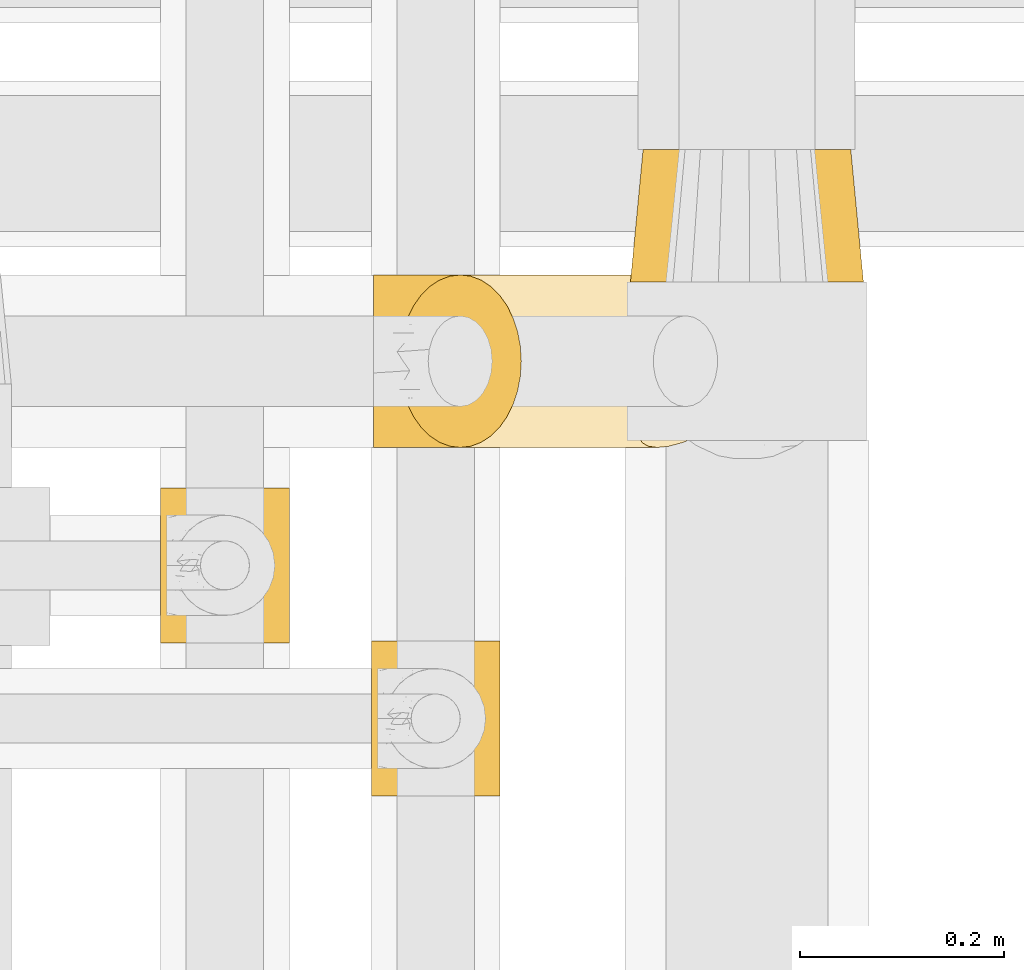
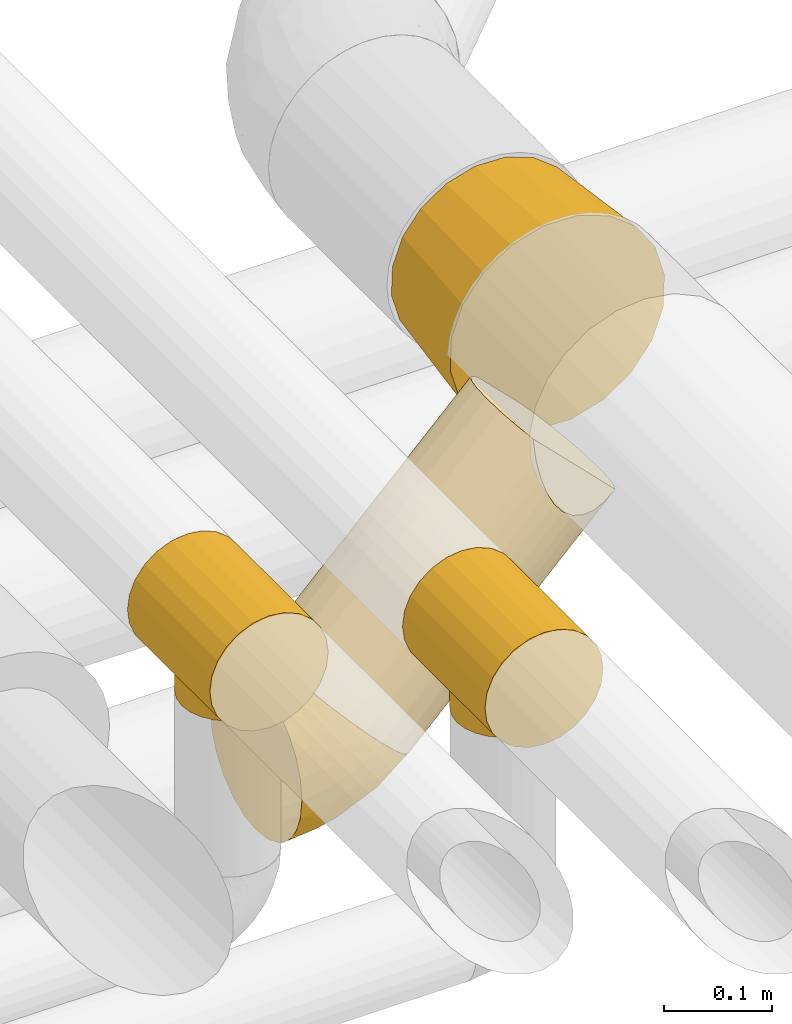
# One storey, part 32 of 93: 5 coverings.
"""IFC2X3 building model written with IfcOpenShell, lengths in millimetres."""

from ifc_helpers import new_model, entity, si_unit, converted_unit, derived_unit, direction, frame, origin, place, context, subcontext, project, spatial, faceted_brep, element, save


model = new_model("IFC2X3")

# Units and contexts
model_context = context("Model", 3, precision=0.01, world=origin(), true_north=direction((6.12303176911189e-17, 1.0)))
body_context = subcontext(model_context, "Body", "Model", "MODEL_VIEW")
ifc_project = project(units=[si_unit("LENGTHUNIT", "METRE", prefix="MILLI"), si_unit("AREAUNIT", "SQUARE_METRE"), si_unit("VOLUMEUNIT", "CUBIC_METRE"), converted_unit("PLANEANGLEUNIT", "DEGREE", entity("IfcRatioMeasure", 0.0174532925199433), si_unit("PLANEANGLEUNIT", "RADIAN"), dimensions=[0, 0, 0, 0, 0, 0, 0]), si_unit("MASSUNIT", "GRAM", prefix="KILO"), derived_unit("MASSDENSITYUNIT", [(si_unit("MASSUNIT", "GRAM", prefix="KILO"), 1), (si_unit("LENGTHUNIT", "METRE"), -3)]), derived_unit("MOMENTOFINERTIAUNIT", [(si_unit("LENGTHUNIT", "METRE"), 4)]), si_unit("TIMEUNIT", "SECOND"), si_unit("FREQUENCYUNIT", "HERTZ"), si_unit("THERMODYNAMICTEMPERATUREUNIT", "DEGREE_CELSIUS"), derived_unit("THERMALTRANSMITTANCEUNIT", [(si_unit("MASSUNIT", "GRAM", prefix="KILO"), 1), (si_unit("THERMODYNAMICTEMPERATUREUNIT", "KELVIN"), -1), (si_unit("TIMEUNIT", "SECOND"), -3)]), derived_unit("VOLUMETRICFLOWRATEUNIT", [(si_unit("LENGTHUNIT", "METRE"), 3), (si_unit("TIMEUNIT", "SECOND"), -1)]), derived_unit("MASSFLOWRATEUNIT", [(si_unit("MASSUNIT", "GRAM", prefix="KILO"), 1), (si_unit("TIMEUNIT", "SECOND"), -1)]), derived_unit("ROTATIONALFREQUENCYUNIT", [(si_unit("TIMEUNIT", "SECOND"), -1)]), si_unit("ELECTRICCURRENTUNIT", "AMPERE"), si_unit("ELECTRICVOLTAGEUNIT", "VOLT"), si_unit("POWERUNIT", "WATT"), si_unit("FORCEUNIT", "NEWTON", prefix="KILO"), si_unit("ILLUMINANCEUNIT", "LUX"), si_unit("LUMINOUSFLUXUNIT", "LUMEN"), si_unit("LUMINOUSINTENSITYUNIT", "CANDELA"), derived_unit("USERDEFINED", [(si_unit("MASSUNIT", "GRAM", prefix="KILO"), -1), (si_unit("LENGTHUNIT", "METRE"), -2), (si_unit("TIMEUNIT", "SECOND"), 3), (si_unit("LUMINOUSFLUXUNIT", "LUMEN"), 1)]), derived_unit("LINEARVELOCITYUNIT", [(si_unit("LENGTHUNIT", "METRE"), 1), (si_unit("TIMEUNIT", "SECOND"), -1)]), si_unit("PRESSUREUNIT", "PASCAL"), derived_unit("USERDEFINED", [(si_unit("LENGTHUNIT", "METRE"), -2), (si_unit("MASSUNIT", "GRAM", prefix="KILO"), 1), (si_unit("TIMEUNIT", "SECOND"), -2)]), derived_unit("LINEARFORCEUNIT", [(si_unit("MASSUNIT", "GRAM", prefix="KILO"), 1), (si_unit("LENGTHUNIT", "METRE"), 1), (si_unit("TIMEUNIT", "SECOND"), -2), (si_unit("LENGTHUNIT", "METRE"), -1)]), derived_unit("PLANARFORCEUNIT", [(si_unit("MASSUNIT", "GRAM", prefix="KILO"), 1), (si_unit("LENGTHUNIT", "METRE"), 1), (si_unit("TIMEUNIT", "SECOND"), -2), (si_unit("LENGTHUNIT", "METRE"), -2)])], contexts=[model_context])

# Site, building, storey
site_placement = place(None, origin())
site = spatial("IfcSite", under=ifc_project, at=site_placement, CompositionType="ELEMENT")
building_placement = place(site_placement, origin())
building = spatial("IfcBuilding", under=site, at=building_placement, CompositionType="ELEMENT")
storey_placement = place(building_placement, frame((0.0, 0.0, -4200.0)))
storey = spatial("IfcBuildingStorey", under=building, at=storey_placement, CompositionType="ELEMENT", Elevation=-4200.0)

# Coverings
covering_1_placement = place(storey_placement, frame((24612.11, 8975.05, 2601.77)))
element("IfcCovering", 1, at=covering_1_placement, inside=storey, Name=":ADSK_", ObjectType=":ADSK_", PredefinedType="INSULATION", context=body_context, shape_type="Brep", body=[
    faceted_brep([(30.3, 57.19, 177.39), (34.7, 43.84, 172.99), (40.68, 31.78, 167.01), (48.04, 21.36, 159.65), (56.57, 12.92, 151.12), (66.01, 6.69, 141.68), (76.07, 2.88, 131.62), (86.45, 1.6, 121.24), (96.83, 2.88, 110.86), (106.89, 6.69, 100.8), (116.33, 12.92, 91.36), (124.86, 21.37, 82.83), (132.22, 31.78, 75.47), (138.19, 43.85, 69.5), (142.59, 57.19, 65.1), (145.29, 71.42, 62.4), (146.2, 86.1, 61.49), (145.29, 100.77, 62.4), (142.59, 115.0, 65.1), (138.19, 128.35, 69.5), (132.22, 140.41, 75.47), (124.85, 150.83, 82.84), (116.32, 159.27, 91.37), (106.88, 165.5, 100.81), (96.82, 169.31, 110.87), (86.45, 170.6, 121.24), (76.07, 169.31, 131.62), (66.01, 165.5, 141.68), (56.57, 159.27, 151.12), (48.04, 150.82, 159.65), (40.68, 140.41, 167.02), (34.7, 128.34, 172.99), (30.3, 115.0, 177.39), (27.61, 100.77, 180.09), (26.7, 86.1, 180.99), (27.61, 71.42, 180.08), (1.6, 86.1, 170.6), (1.6, 107.97, 167.72), (1.6, 128.35, 159.27), (1.6, 145.85, 145.85), (1.6, 159.27, 128.35), (1.6, 167.72, 107.97), (1.6, 170.6, 86.1), (1.6, 167.72, 64.23), (1.6, 159.27, 43.85), (1.6, 145.85, 26.34), (1.6, 128.35, 12.92), (1.6, 107.97, 4.47), (1.6, 86.1, 1.6), (1.6, 64.23, 4.47), (1.6, 43.85, 12.92), (1.6, 26.34, 26.34), (1.6, 12.92, 43.85), (1.6, 4.47, 64.23), (1.6, 1.6, 86.1), (1.6, 4.47, 107.97), (1.6, 12.92, 128.35), (1.6, 26.34, 145.85), (1.6, 43.85, 159.27), (1.6, 64.23, 167.72), (62.78, 11.6, 58.38), (90.49, 10.46, 75.86), (55.14, 3.98, 76.82), (41.49, 86.1, 5.52), (59.49, 62.28, 13.54), (79.85, 86.1, 17.16), (111.26, 65.23, 36.6), (74.72, 40.39, 29.57), (51.95, 24.01, 36.08), (35.79, 36.3, 20.96), (32.65, 1.6, 90.18), (108.5, 41.73, 46.71), (61.6, 1.6, 102.17), (47.12, 1.6, 96.18), (28.84, 8.85, 54.26), (96.96, 27.98, 51.85), (85.42, 18.02, 58.13), (16.49, 1.6, 88.06), (115.21, 86.1, 36.06), (74.53, 1.6, 112.1), (36.37, 22.14, 151.45), (31.33, 34.55, 162.16), (22.95, 31.16, 154.55), (18.73, 4.91, 111.05), (17.11, 14.78, 133.05), (26.82, 18.65, 141.78), (53.13, 5.78, 127.81), (38.8, 3.53, 111.1), (35.04, 9.14, 127.85), (14.25, 25.56, 146.38), (15.18, 86.1, 173.3), (17.08, 61.0, 169.96), (21.35, 45.18, 164.48), (10.26, 50.94, 163.81), (25.52, 7.64, 120.77), (43.12, 12.19, 138.86), (67.11, 3.03, 124.67), (21.35, 127.0, 164.48), (10.26, 121.25, 163.82), (17.08, 111.19, 169.96), (22.95, 141.03, 154.55), (14.25, 146.82, 146.18), (25.51, 164.55, 120.77), (17.11, 157.41, 133.05), (35.03, 163.04, 127.85), (18.73, 167.28, 111.05), (16.49, 170.6, 88.06), (53.13, 166.41, 127.81), (46.6, 159.13, 143.0), (36.37, 150.04, 151.46), (31.32, 137.64, 162.17), (26.82, 153.53, 141.78), (32.65, 170.6, 90.18), (61.6, 170.6, 102.17), (67.1, 169.16, 124.67), (74.53, 170.6, 112.1), (38.79, 168.66, 111.1), (47.12, 170.6, 96.18), (55.14, 168.21, 76.82), (51.95, 148.19, 36.08), (85.42, 154.17, 58.13), (96.96, 144.21, 51.86), (111.26, 106.96, 36.59), (90.49, 161.73, 75.86), (62.78, 160.59, 58.38), (35.78, 135.89, 20.96), (59.49, 109.91, 13.54), (74.71, 131.8, 29.57), (28.83, 163.34, 54.26), (108.5, 130.47, 46.72)], [[[0, 1, 2, 3, 4, 5, 6, 7, 8, 9, 10, 11, 12, 13, 14, 15, 16, 17, 18, 19, 20, 21, 22, 23, 24, 25, 26, 27, 28, 29, 30, 31, 32, 33, 34, 35]], [[36, 37, 38, 39, 40, 41, 42, 43, 44, 45, 46, 47, 48, 49, 50, 51, 52, 53, 54, 55, 56, 57, 58, 59]], [[60, 61, 62]], [[49, 48, 63]], [[64, 63, 65]], [[65, 66, 64]], [[9, 8, 62]], [[67, 68, 69]], [[53, 62, 70]], [[71, 14, 13]], [[62, 72, 73, 70]], [[74, 53, 52]], [[75, 76, 68]], [[76, 10, 61]], [[52, 51, 68]], [[53, 70, 77, 54]], [[74, 62, 53]], [[50, 49, 64]], [[67, 75, 68]], [[64, 67, 69]], [[66, 65, 78]], [[66, 67, 64]], [[75, 71, 12]], [[66, 14, 71]], [[15, 14, 66]], [[15, 78, 16]], [[51, 69, 68]], [[12, 71, 13]], [[12, 11, 75]], [[66, 71, 67]], [[62, 8, 72]], [[8, 7, 79, 72]], [[69, 51, 50]], [[68, 60, 74]], [[75, 67, 71]], [[9, 61, 10]], [[68, 76, 60]], [[76, 61, 60]], [[10, 76, 11]], [[62, 61, 9]], [[11, 76, 75]], [[78, 15, 66]], [[64, 69, 50]], [[49, 63, 64]], [[68, 74, 52]], [[62, 74, 60]], [[80, 81, 82]], [[70, 83, 77]], [[56, 84, 57]], [[77, 83, 55]], [[1, 81, 2]], [[85, 80, 82]], [[86, 87, 72]], [[88, 87, 86]], [[57, 89, 58]], [[90, 59, 91]], [[92, 81, 1]], [[90, 36, 59]], [[35, 34, 90]], [[83, 84, 56]], [[92, 93, 82]], [[90, 91, 35]], [[70, 73, 72, 87]], [[84, 94, 88]], [[3, 95, 4]], [[80, 95, 3]], [[86, 95, 88]], [[79, 6, 96]], [[7, 6, 79]], [[96, 72, 79]], [[1, 0, 92]], [[93, 92, 91]], [[81, 80, 2]], [[35, 91, 0]], [[84, 85, 89]], [[91, 92, 0]], [[2, 80, 3]], [[55, 83, 56]], [[81, 92, 82]], [[59, 58, 93]], [[96, 6, 5]], [[4, 86, 5]], [[5, 86, 96]], [[95, 85, 88]], [[72, 96, 86]], [[59, 93, 91]], [[82, 93, 58]], [[89, 85, 82]], [[88, 85, 84]], [[58, 89, 82]], [[84, 89, 57]], [[87, 88, 94]], [[55, 54, 77]], [[4, 95, 86]], [[85, 95, 80]], [[84, 83, 94]], [[83, 70, 87]], [[87, 94, 83]], [[97, 98, 99]], [[38, 100, 101]], [[32, 97, 99]], [[102, 103, 104]], [[90, 33, 99]], [[36, 90, 37]], [[90, 99, 37]], [[37, 99, 98]], [[105, 106, 41]], [[103, 105, 40]], [[107, 108, 28]], [[109, 110, 30]], [[109, 111, 100]], [[105, 41, 40]], [[106, 105, 112]], [[97, 110, 100]], [[90, 34, 33]], [[113, 114, 115]], [[32, 31, 97]], [[26, 25, 115]], [[104, 108, 107]], [[39, 103, 40]], [[116, 112, 105]], [[109, 100, 110]], [[30, 29, 109]], [[110, 31, 30]], [[108, 104, 111]], [[28, 27, 107]], [[31, 110, 97]], [[114, 27, 26]], [[107, 114, 113]], [[115, 114, 26]], [[111, 104, 103]], [[29, 28, 108]], [[98, 100, 38]], [[32, 99, 33]], [[103, 101, 111]], [[116, 107, 113]], [[107, 27, 114]], [[100, 98, 97]], [[37, 98, 38]], [[111, 109, 108]], [[101, 103, 39]], [[38, 101, 39]], [[100, 111, 101]], [[116, 113, 117, 112]], [[102, 116, 105]], [[106, 42, 41]], [[29, 108, 109]], [[116, 102, 104]], [[105, 103, 102]], [[107, 116, 104]], [[43, 112, 118]], [[119, 120, 121]], [[121, 120, 21]], [[65, 122, 78]], [[118, 112, 117, 113]], [[43, 42, 106, 112]], [[120, 123, 22]], [[120, 119, 124]], [[63, 48, 47]], [[45, 125, 46]], [[126, 125, 127]], [[125, 126, 46]], [[46, 126, 47]], [[119, 44, 128]], [[125, 45, 119]], [[126, 65, 63]], [[129, 19, 18]], [[43, 128, 44]], [[118, 24, 23]], [[20, 129, 121]], [[118, 23, 123]], [[22, 21, 120]], [[121, 21, 20]], [[125, 119, 127]], [[122, 126, 127]], [[22, 123, 23]], [[44, 119, 45]], [[19, 129, 20]], [[122, 18, 17]], [[121, 129, 127]], [[120, 124, 123]], [[65, 126, 122]], [[17, 16, 78]], [[118, 124, 128]], [[24, 118, 113]], [[78, 122, 17]], [[119, 121, 127]], [[18, 122, 129]], [[47, 126, 63]], [[24, 113, 115, 25]], [[118, 123, 124]], [[122, 127, 129]], [[118, 128, 43]], [[119, 128, 124]]]),
])
covering_2_placement = place(storey_placement, frame((24637.21, 8975.05, 2661.67)))
element("IfcCovering", 2, at=covering_2_placement, inside=storey, Name=":ADSK_", ObjectType=":ADSK_", PredefinedType="INSULATION", context=body_context, shape_type="Brep", body=[
    faceted_brep([(9.6, 43.85, 113.09), (3.63, 64.23, 119.06), (1.6, 86.1, 121.1), (3.63, 107.97, 119.06), (9.6, 128.35, 113.09), (19.1, 145.85, 103.6), (31.47, 159.27, 91.22), (45.88, 167.72, 76.81), (61.35, 170.6, 61.35), (76.81, 167.72, 45.88), (91.22, 159.27, 31.47), (103.6, 145.85, 19.1), (113.09, 128.35, 9.6), (119.06, 107.97, 3.63), (121.1, 86.1, 1.6), (119.06, 64.23, 3.63), (113.09, 43.85, 9.6), (103.6, 26.34, 19.1), (91.22, 12.92, 31.47), (76.81, 4.47, 45.88), (61.35, 1.6, 61.35), (45.88, 4.47, 76.81), (31.47, 12.92, 91.22), (19.1, 26.34, 103.6), (224.19, 107.97, 339.62), (222.15, 86.1, 341.65), (224.0, 65.21, 339.8), (229.45, 45.63, 334.36), (238.14, 28.55, 325.66), (325.89, 28.91, 237.92), (334.46, 45.91, 229.34), (339.83, 65.37, 223.98), (341.65, 86.1, 222.15), (339.62, 107.97, 224.19), (333.65, 128.35, 230.16), (324.15, 145.85, 239.65), (311.78, 159.27, 252.03), (297.37, 167.72, 266.44), (281.9, 170.6, 281.9), (266.44, 167.72, 297.37), (252.03, 159.27, 311.78), (239.65, 145.85, 324.15), (230.16, 128.35, 333.65), (309.03, 19.44, 235.59), (293.03, 11.8, 236.11), (278.32, 6.18, 239.49), (265.3, 2.75, 245.61), (254.32, 1.6, 254.32), (245.74, 2.73, 265.29), (239.71, 6.12, 278.28), (236.38, 11.66, 292.95), (235.86, 19.21, 308.88)], [[[0, 1, 2, 3, 4, 5, 6, 7, 8, 9, 10, 11, 12, 13, 14, 15, 16, 17, 18, 19, 20, 21, 22, 23]], [[24, 25, 26, 27, 28, 29, 30, 31, 32, 33, 34, 35, 36, 37, 38, 39, 40, 41, 42]], [[24, 42, 4, 3]], [[25, 24, 3, 2]], [[42, 41, 5, 4]], [[7, 6, 40, 39]], [[8, 7, 39, 38]], [[41, 40, 6, 5]], [[9, 8, 38, 37]], [[10, 9, 37, 36]], [[36, 35, 11, 10]], [[13, 12, 34, 33]], [[14, 13, 33, 32]], [[35, 34, 12, 11]], [[14, 32, 31]], [[15, 31, 30]], [[16, 30, 29]], [[14, 31, 15]], [[15, 30, 16]], [[29, 17, 16]], [[29, 43, 17]], [[43, 44, 18]], [[45, 46, 19]], [[44, 45, 18]], [[18, 45, 19]], [[20, 19, 46]], [[47, 20, 46]], [[43, 18, 17]], [[48, 49, 21]], [[50, 51, 22]], [[49, 50, 22]], [[47, 48, 20]], [[20, 48, 21]], [[49, 22, 21]], [[51, 23, 22]], [[0, 28, 27]], [[1, 27, 26]], [[2, 26, 25]], [[23, 28, 0]], [[0, 27, 1]], [[26, 2, 1]], [[28, 23, 51]], [[50, 49, 48, 47, 46, 45, 44, 43, 29, 28, 51]]]),
])
covering_3_placement = place(storey_placement, frame((24863.6, 9138.64, 2884.3)))
element("IfcCovering", 3, at=covering_3_placement, inside=storey, Name=":ADSK_", ObjectType=":ADSK_", PredefinedType="INSULATION", context=body_context, shape_type="Brep", body=[
    faceted_brep([(72.13, 130.0, 208.48), (102.93, 130.0, 217.4), (134.98, 130.0, 216.37), (165.15, 130.0, 205.48), (190.47, 130.0, 185.81), (208.48, 130.0, 159.27), (217.4, 130.0, 128.47), (216.37, 130.0, 96.42), (205.48, 130.0, 66.25), (185.81, 130.0, 40.93), (159.27, 130.0, 22.92), (128.47, 130.0, 14.0), (96.42, 130.0, 15.03), (66.25, 130.0, 25.92), (40.93, 130.0, 45.59), (22.92, 130.0, 72.13), (14.0, 130.0, 102.93), (15.03, 130.0, 134.98), (25.92, 130.0, 165.15), (45.59, 130.0, 190.47), (37.04, 0.0, 199.59), (14.97, 0.0, 171.18), (2.75, 0.0, 137.34), (1.6, 0.0, 101.37), (11.61, 0.0, 66.81), (31.81, 0.0, 37.04), (60.22, 0.0, 14.97), (94.06, 0.0, 2.75), (130.03, 0.0, 1.6), (164.58, 0.0, 11.61), (194.36, 0.0, 31.81), (216.43, 0.0, 60.22), (228.65, 0.0, 94.06), (229.8, 0.0, 130.03), (219.79, 0.0, 164.58), (199.59, 0.0, 194.36), (171.18, 0.0, 216.43), (137.34, 0.0, 228.65), (101.37, 0.0, 229.8), (66.81, 0.0, 219.79)], [[[0, 1, 2, 3, 4, 5, 6, 7, 8, 9, 10, 11, 12, 13, 14, 15, 16, 17, 18, 19]], [[20, 21, 22, 23, 24, 25, 26, 27, 28, 29, 30, 31, 32, 33, 34, 35, 36, 37, 38, 39]], [[8, 7, 32, 31]], [[9, 8, 31, 30]], [[7, 6, 33, 32]], [[34, 33, 6, 5]], [[34, 5, 4, 35]], [[13, 12, 27, 26]], [[14, 13, 26, 25]], [[12, 11, 28, 27]], [[29, 28, 11, 10]], [[29, 10, 9, 30]], [[18, 17, 22, 21]], [[19, 18, 21, 20]], [[17, 16, 23, 22]], [[24, 23, 16, 15]], [[24, 15, 14, 25]], [[3, 2, 37, 36]], [[4, 3, 36, 35]], [[2, 1, 38, 37]], [[39, 38, 1, 0]], [[39, 0, 19, 20]]]),
])
covering_4_placement = place(storey_placement, frame((24403.4, 8785.14, 2933.0)))
element("IfcCovering", 4, at=covering_4_placement, inside=storey, Name=":ADSK_", ObjectType=":ADSK_", PredefinedType="INSULATION", context=body_context, shape_type="Brep", body=[
    faceted_brep([(96.17, 0.0, 121.6), (80.96, 0.0, 127.9), (64.65, 0.0, 130.05), (48.33, 0.0, 127.9), (33.12, 0.0, 121.6), (20.06, 0.0, 111.58), (10.04, 0.0, 98.53), (3.74, 0.0, 83.32), (1.6, 0.0, 67.0), (3.74, 0.0, 50.68), (10.04, 0.0, 35.48), (20.06, 0.0, 22.42), (26.59, 0.0, 17.41), (33.12, 0.0, 12.4), (40.72, 0.0, 9.25), (48.33, 0.0, 6.1), (56.49, 0.0, 5.02), (64.65, 0.0, 3.95), (72.8, 0.0, 5.02), (80.96, 0.0, 6.1), (88.57, 0.0, 9.25), (96.17, 0.0, 12.4), (102.7, 0.0, 17.41), (109.23, 0.0, 22.42), (119.25, 0.0, 35.48), (125.55, 0.0, 50.68), (127.7, 0.0, 67.0), (125.55, 0.0, 83.32), (119.25, 0.0, 98.53), (109.23, 0.0, 111.58), (1.6, 152.0, 67.0), (3.74, 152.0, 83.32), (10.04, 152.0, 98.53), (20.06, 152.0, 111.58), (33.12, 152.0, 121.6), (48.33, 152.0, 127.9), (64.65, 152.0, 130.05), (80.96, 152.0, 127.9), (96.17, 152.0, 121.6), (109.23, 152.0, 111.58), (119.25, 152.0, 98.53), (125.55, 152.0, 83.32), (127.7, 152.0, 67.0), (125.55, 152.0, 50.68), (119.25, 152.0, 35.48), (109.23, 152.0, 22.42), (102.7, 152.0, 17.41), (96.17, 152.0, 12.4), (88.57, 152.0, 9.25), (80.96, 152.0, 6.1), (72.8, 152.0, 5.02), (64.65, 152.0, 3.95), (56.49, 152.0, 5.02), (48.33, 152.0, 6.1), (40.72, 152.0, 9.25), (33.12, 152.0, 12.4), (26.59, 152.0, 17.41), (20.06, 152.0, 22.42), (10.04, 152.0, 35.48), (3.74, 152.0, 50.68), (26.16, 106.57, 17.06), (20.53, 97.67, 21.96), (33.55, 114.06, 12.15), (42.62, 32.06, 7.92), (16.83, 87.39, 25.9), (15.5, 76.0, 27.51), (16.83, 64.61, 25.9), (58.91, 27.53, 4.48), (64.65, 26.85, 3.95), (64.65, 125.15, 3.95), (58.91, 124.47, 4.48), (26.16, 45.43, 17.06), (20.53, 54.33, 21.96), (33.55, 37.94, 12.15), (42.62, 119.94, 7.92), (47.9, 30.13, 6.46), (53.17, 28.21, 5.0), (53.17, 123.79, 5.0), (47.9, 121.87, 6.46), (70.38, 124.47, 4.48), (76.12, 123.79, 5.0), (95.74, 114.06, 12.15), (86.67, 119.94, 7.92), (81.39, 121.87, 6.46), (76.12, 28.21, 5.0), (70.38, 27.53, 4.48), (95.74, 37.94, 12.15), (86.67, 32.06, 7.92), (103.13, 45.43, 17.06), (81.39, 30.13, 6.46), (103.13, 106.57, 17.06), (108.76, 97.67, 21.96), (112.46, 87.39, 25.9), (113.8, 76.0, 27.51), (108.76, 54.33, 21.96), (112.46, 64.61, 25.9), (17.17, 88.72, 0.0), (22.08, 100.57, 0.0), (29.89, 110.75, 0.0), (40.07, 118.57, 0.0), (46.0, 121.02, 0.0), (51.92, 123.48, 0.0), (58.28, 124.31, 0.0), (64.65, 125.15, 0.0), (71.01, 124.31, 0.0), (77.37, 123.48, 0.0), (83.29, 121.02, 0.0), (89.22, 118.57, 0.0), (99.4, 110.75, 0.0), (107.21, 100.57, 0.0), (112.12, 88.72, 0.0), (113.8, 76.0, 0.0), (112.12, 63.28, 0.0), (107.21, 51.42, 0.0), (99.4, 41.25, 0.0), (89.22, 33.43, 0.0), (83.29, 30.98, 0.0), (77.37, 28.52, 0.0), (71.01, 27.69, 0.0), (64.65, 26.85, 0.0), (58.28, 27.69, 0.0), (51.92, 28.52, 0.0), (46.0, 30.98, 0.0), (40.07, 33.43, 0.0), (29.89, 41.25, 0.0), (22.08, 51.42, 0.0), (17.17, 63.28, 0.0), (15.5, 76.0, 0.0)], [[[0, 1, 2, 3, 4, 5, 6, 7, 8, 9, 10, 11, 12, 13, 14, 15, 16, 17, 18, 19, 20, 21, 22, 23, 24, 25, 26, 27, 28, 29]], [[30, 31, 32, 33, 34, 35, 36, 37, 38, 39, 40, 41, 42, 43, 44, 45, 46, 47, 48, 49, 50, 51, 52, 53, 54, 55, 56, 57, 58, 59]], [[34, 33, 5, 4]], [[2, 36, 35, 3]], [[4, 3, 35, 34]], [[6, 32, 31, 7]], [[7, 31, 30, 8]], [[5, 33, 32, 6]], [[59, 9, 8, 30]], [[58, 10, 9, 59]], [[57, 60, 61]], [[56, 55, 62]], [[63, 15, 14]], [[61, 64, 57]], [[60, 57, 56]], [[57, 64, 58]], [[64, 65, 58]], [[66, 11, 10]], [[17, 67, 68]], [[69, 70, 51]], [[71, 11, 72]], [[72, 11, 66]], [[73, 12, 71]], [[66, 10, 65]], [[65, 10, 58]], [[62, 54, 74]], [[54, 62, 55]], [[74, 54, 53]], [[15, 63, 75, 76]], [[77, 53, 52]], [[51, 70, 52]], [[77, 52, 70]], [[53, 77, 78, 74]], [[73, 13, 12]], [[73, 14, 13]], [[14, 73, 63]], [[16, 76, 67]], [[71, 12, 11]], [[17, 16, 67]], [[16, 15, 76]], [[60, 56, 62]], [[50, 79, 51]], [[80, 50, 49]], [[47, 81, 48]], [[82, 48, 81]], [[82, 49, 48]], [[49, 82, 83, 80]], [[50, 80, 79]], [[84, 18, 85]], [[85, 17, 68]], [[51, 79, 69]], [[86, 21, 20]], [[17, 85, 18]], [[20, 19, 87]], [[86, 88, 22]], [[87, 19, 84, 89]], [[81, 46, 90]], [[81, 47, 46]], [[90, 45, 91]], [[45, 90, 46]], [[91, 45, 92]], [[24, 44, 43, 25]], [[93, 92, 44]], [[44, 92, 45]], [[43, 42, 26, 25]], [[84, 19, 18]], [[94, 95, 23]], [[86, 20, 87]], [[22, 21, 86]], [[23, 88, 94]], [[95, 24, 23]], [[93, 24, 95]], [[93, 44, 24]], [[88, 23, 22]], [[27, 41, 40, 28]], [[28, 40, 39, 29]], [[42, 41, 27, 26]], [[0, 38, 37, 1]], [[1, 37, 36, 2]], [[29, 39, 38, 0]], [[96, 97, 98, 99, 100, 101, 102, 103, 104, 105, 106, 107, 108, 109, 110, 111, 112, 113, 114, 115, 116, 117, 118, 119, 120, 121, 122, 123, 124, 125, 126, 127]], [[77, 102, 101]], [[74, 100, 99]], [[103, 70, 69]], [[103, 102, 70]], [[101, 78, 77]], [[62, 74, 99]], [[100, 78, 101]], [[100, 74, 78]], [[99, 98, 62]], [[60, 98, 97]], [[96, 127, 64]], [[102, 77, 70]], [[61, 97, 96]], [[60, 97, 61]], [[64, 61, 96]], [[65, 64, 127]], [[98, 60, 62]], [[66, 127, 126]], [[72, 126, 125]], [[65, 127, 66]], [[119, 67, 120]], [[66, 126, 72]], [[125, 71, 72]], [[125, 124, 71]], [[73, 124, 123]], [[76, 75, 121]], [[67, 119, 68]], [[76, 121, 120]], [[63, 73, 123]], [[63, 123, 122]], [[76, 120, 67]], [[122, 75, 63]], [[121, 75, 122]], [[124, 73, 71]], [[84, 118, 117]], [[87, 116, 115]], [[119, 85, 68]], [[119, 118, 85]], [[117, 89, 84]], [[86, 87, 115]], [[116, 89, 117]], [[118, 84, 85]], [[115, 114, 86]], [[88, 114, 113]], [[113, 112, 94]], [[111, 95, 112]], [[116, 87, 89]], [[88, 113, 94]], [[95, 94, 112]], [[93, 95, 111]], [[114, 88, 86]], [[92, 111, 110]], [[91, 110, 109]], [[93, 111, 92]], [[103, 79, 104]], [[92, 110, 91]], [[109, 90, 91]], [[109, 108, 90]], [[81, 108, 107]], [[80, 83, 105]], [[79, 103, 69]], [[80, 105, 104]], [[82, 81, 107]], [[82, 107, 106]], [[80, 104, 79]], [[106, 83, 82]], [[105, 83, 106]], [[108, 81, 90]]]),
])
covering_5_placement = place(storey_placement, frame((24609.81, 8635.14, 2933.0)))
element("IfcCovering", 5, at=covering_5_placement, inside=storey, Name=":ADSK_", ObjectType=":ADSK_", PredefinedType="INSULATION", context=body_context, shape_type="Brep", body=[
    faceted_brep([(96.17, 0.0, 121.6), (80.96, 0.0, 127.9), (64.65, 0.0, 130.05), (48.33, 0.0, 127.9), (33.12, 0.0, 121.6), (20.06, 0.0, 111.58), (10.04, 0.0, 98.53), (3.74, 0.0, 83.32), (1.6, 0.0, 67.0), (3.74, 0.0, 50.68), (10.04, 0.0, 35.48), (20.06, 0.0, 22.42), (26.59, 0.0, 17.41), (33.12, 0.0, 12.4), (40.72, 0.0, 9.25), (48.33, 0.0, 6.1), (56.49, 0.0, 5.02), (64.65, 0.0, 3.95), (72.8, 0.0, 5.02), (80.96, 0.0, 6.1), (88.57, 0.0, 9.25), (96.17, 0.0, 12.4), (102.7, 0.0, 17.41), (109.23, 0.0, 22.42), (119.25, 0.0, 35.48), (125.55, 0.0, 50.68), (127.7, 0.0, 67.0), (125.55, 0.0, 83.32), (119.25, 0.0, 98.53), (109.23, 0.0, 111.58), (1.6, 152.0, 67.0), (3.74, 152.0, 83.32), (10.04, 152.0, 98.53), (20.06, 152.0, 111.58), (33.12, 152.0, 121.6), (48.33, 152.0, 127.9), (64.65, 152.0, 130.05), (80.96, 152.0, 127.9), (96.17, 152.0, 121.6), (109.23, 152.0, 111.58), (119.25, 152.0, 98.53), (125.55, 152.0, 83.32), (127.7, 152.0, 67.0), (125.55, 152.0, 50.68), (119.25, 152.0, 35.48), (109.23, 152.0, 22.42), (102.7, 152.0, 17.41), (96.17, 152.0, 12.4), (88.57, 152.0, 9.25), (80.96, 152.0, 6.1), (72.8, 152.0, 5.02), (64.65, 152.0, 3.95), (56.49, 152.0, 5.02), (48.33, 152.0, 6.1), (40.72, 152.0, 9.25), (33.12, 152.0, 12.4), (26.59, 152.0, 17.41), (20.06, 152.0, 22.42), (10.04, 152.0, 35.48), (3.74, 152.0, 50.68), (26.16, 106.57, 17.06), (20.53, 97.67, 21.96), (33.55, 114.06, 12.15), (42.62, 32.06, 7.92), (16.83, 87.39, 25.9), (15.5, 76.0, 27.51), (16.83, 64.61, 25.9), (58.91, 27.53, 4.48), (64.65, 26.85, 3.95), (64.65, 125.15, 3.95), (58.91, 124.47, 4.48), (26.16, 45.43, 17.06), (20.53, 54.33, 21.96), (33.55, 37.94, 12.15), (42.62, 119.94, 7.92), (47.9, 30.13, 6.46), (53.17, 28.21, 5.0), (53.17, 123.79, 5.0), (47.9, 121.87, 6.46), (70.38, 124.47, 4.48), (76.12, 123.79, 5.0), (95.74, 114.06, 12.15), (86.67, 119.94, 7.92), (81.39, 121.87, 6.46), (76.12, 28.21, 5.0), (70.38, 27.53, 4.48), (95.74, 37.94, 12.15), (86.67, 32.06, 7.92), (103.13, 45.43, 17.06), (81.39, 30.13, 6.46), (103.13, 106.57, 17.06), (108.76, 97.67, 21.96), (112.46, 87.39, 25.9), (113.8, 76.0, 27.51), (108.76, 54.33, 21.96), (112.46, 64.61, 25.9), (17.17, 88.72, 0.0), (22.08, 100.57, 0.0), (29.89, 110.75, 0.0), (40.07, 118.57, 0.0), (46.0, 121.02, 0.0), (51.92, 123.48, 0.0), (58.28, 124.31, 0.0), (64.65, 125.15, 0.0), (71.01, 124.31, 0.0), (77.37, 123.48, 0.0), (83.29, 121.02, 0.0), (89.22, 118.57, 0.0), (99.4, 110.75, 0.0), (107.21, 100.57, 0.0), (112.12, 88.72, 0.0), (113.8, 76.0, 0.0), (112.12, 63.28, 0.0), (107.21, 51.42, 0.0), (99.4, 41.25, 0.0), (89.22, 33.43, 0.0), (83.29, 30.98, 0.0), (77.37, 28.52, 0.0), (71.01, 27.69, 0.0), (64.65, 26.85, 0.0), (58.28, 27.69, 0.0), (51.92, 28.52, 0.0), (46.0, 30.98, 0.0), (40.07, 33.43, 0.0), (29.89, 41.25, 0.0), (22.08, 51.42, 0.0), (17.17, 63.28, 0.0), (15.5, 76.0, 0.0)], [[[0, 1, 2, 3, 4, 5, 6, 7, 8, 9, 10, 11, 12, 13, 14, 15, 16, 17, 18, 19, 20, 21, 22, 23, 24, 25, 26, 27, 28, 29]], [[30, 31, 32, 33, 34, 35, 36, 37, 38, 39, 40, 41, 42, 43, 44, 45, 46, 47, 48, 49, 50, 51, 52, 53, 54, 55, 56, 57, 58, 59]], [[34, 33, 5, 4]], [[2, 36, 35, 3]], [[4, 3, 35, 34]], [[6, 32, 31, 7]], [[7, 31, 30, 8]], [[5, 33, 32, 6]], [[59, 9, 8, 30]], [[58, 10, 9, 59]], [[57, 60, 61]], [[56, 55, 62]], [[63, 15, 14]], [[61, 64, 57]], [[60, 57, 56]], [[57, 64, 58]], [[64, 65, 58]], [[66, 11, 10]], [[17, 67, 68]], [[69, 70, 51]], [[71, 11, 72]], [[72, 11, 66]], [[73, 12, 71]], [[66, 10, 65]], [[65, 10, 58]], [[62, 54, 74]], [[54, 62, 55]], [[74, 54, 53]], [[15, 63, 75, 76]], [[77, 53, 52]], [[51, 70, 52]], [[77, 52, 70]], [[53, 77, 78, 74]], [[73, 13, 12]], [[73, 14, 13]], [[14, 73, 63]], [[16, 76, 67]], [[71, 12, 11]], [[17, 16, 67]], [[16, 15, 76]], [[60, 56, 62]], [[50, 79, 51]], [[80, 50, 49]], [[47, 81, 48]], [[82, 48, 81]], [[82, 49, 48]], [[49, 82, 83, 80]], [[50, 80, 79]], [[84, 18, 85]], [[85, 17, 68]], [[51, 79, 69]], [[86, 21, 20]], [[17, 85, 18]], [[20, 19, 87]], [[86, 88, 22]], [[87, 19, 84, 89]], [[81, 46, 90]], [[81, 47, 46]], [[90, 45, 91]], [[45, 90, 46]], [[91, 45, 92]], [[24, 44, 43, 25]], [[93, 92, 44]], [[44, 92, 45]], [[43, 42, 26, 25]], [[84, 19, 18]], [[94, 95, 23]], [[86, 20, 87]], [[22, 21, 86]], [[23, 88, 94]], [[95, 24, 23]], [[93, 24, 95]], [[93, 44, 24]], [[88, 23, 22]], [[27, 41, 40, 28]], [[28, 40, 39, 29]], [[42, 41, 27, 26]], [[0, 38, 37, 1]], [[1, 37, 36, 2]], [[29, 39, 38, 0]], [[96, 97, 98, 99, 100, 101, 102, 103, 104, 105, 106, 107, 108, 109, 110, 111, 112, 113, 114, 115, 116, 117, 118, 119, 120, 121, 122, 123, 124, 125, 126, 127]], [[77, 102, 101]], [[74, 100, 99]], [[103, 70, 69]], [[103, 102, 70]], [[101, 78, 77]], [[62, 74, 99]], [[100, 78, 101]], [[100, 74, 78]], [[99, 98, 62]], [[60, 98, 97]], [[96, 127, 64]], [[102, 77, 70]], [[61, 97, 96]], [[60, 97, 61]], [[64, 61, 96]], [[65, 64, 127]], [[98, 60, 62]], [[66, 127, 126]], [[72, 126, 125]], [[65, 127, 66]], [[119, 67, 120]], [[66, 126, 72]], [[125, 71, 72]], [[125, 124, 71]], [[73, 124, 123]], [[76, 75, 121]], [[67, 119, 68]], [[76, 121, 120]], [[63, 73, 123]], [[63, 123, 122]], [[76, 120, 67]], [[122, 75, 63]], [[121, 75, 122]], [[124, 73, 71]], [[84, 118, 117]], [[87, 116, 115]], [[119, 85, 68]], [[119, 118, 85]], [[117, 89, 84]], [[86, 87, 115]], [[116, 89, 117]], [[118, 84, 85]], [[115, 114, 86]], [[88, 114, 113]], [[113, 112, 94]], [[111, 95, 112]], [[116, 87, 89]], [[88, 113, 94]], [[95, 94, 112]], [[93, 95, 111]], [[114, 88, 86]], [[92, 111, 110]], [[91, 110, 109]], [[93, 111, 92]], [[103, 79, 104]], [[92, 110, 91]], [[109, 90, 91]], [[109, 108, 90]], [[81, 108, 107]], [[80, 83, 105]], [[79, 103, 69]], [[80, 105, 104]], [[82, 81, 107]], [[82, 107, 106]], [[80, 104, 79]], [[106, 83, 82]], [[105, 83, 106]], [[108, 81, 90]]]),
])

save(model, "model.ifc")
